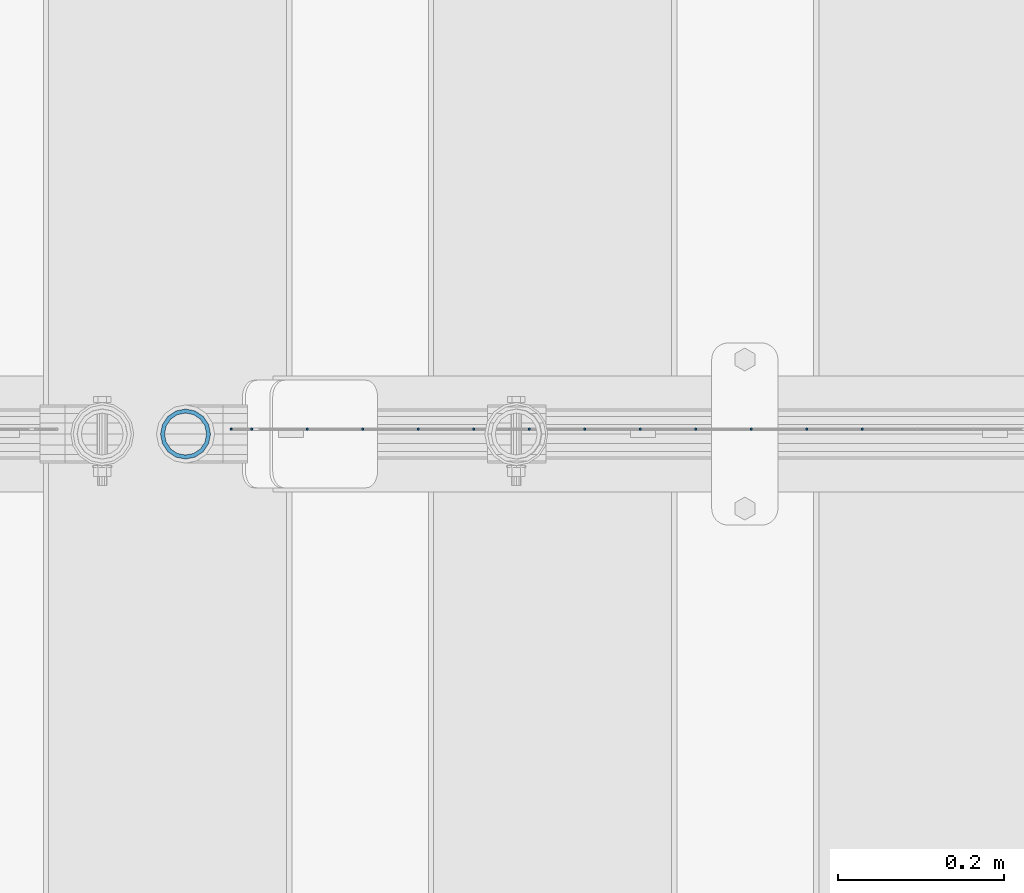
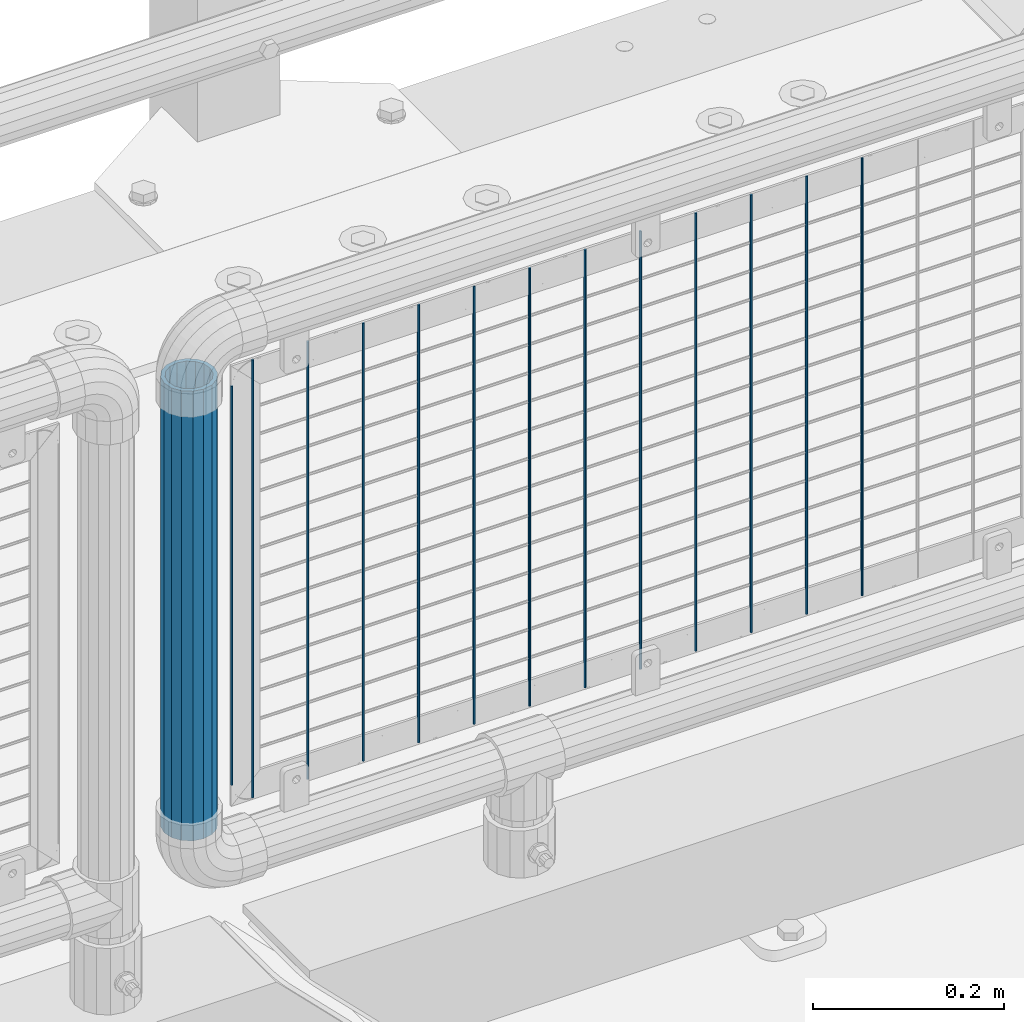
# One storey, part 103 of 247: 14 columns.
"""IFC2X3 building model written with IfcOpenShell, lengths in millimetres."""

from ifc_helpers import new_model, si_unit, frame, origin_with_axes, place, context, subcontext, project, spatial, faceted_brep, material, type_object, element, save


model = new_model("IFC2X3")

# Units and contexts
model_context = context("Model", 3, precision=1e-05, world=origin_with_axes())
body_context = subcontext(model_context, "Body", "Model", "MODEL_VIEW")
ifc_project = project(units=[si_unit("LENGTHUNIT", "METRE", prefix="MILLI"), si_unit("AREAUNIT", "SQUARE_METRE"), si_unit("VOLUMEUNIT", "CUBIC_METRE"), si_unit("MASSUNIT", "GRAM", prefix="KILO"), si_unit("TIMEUNIT", "SECOND"), si_unit("PLANEANGLEUNIT", "RADIAN"), si_unit("SOLIDANGLEUNIT", "STERADIAN"), si_unit("THERMODYNAMICTEMPERATUREUNIT", "DEGREE_CELSIUS"), si_unit("LUMINOUSINTENSITYUNIT", "LUMEN")], contexts=[model_context])

# Site, building, storey
site_placement = place(None, origin_with_axes())
site = spatial("IfcSite", under=ifc_project, at=site_placement, CompositionType="ELEMENT")
building_placement = place(site_placement, origin_with_axes())
building = spatial("IfcBuilding", under=site, at=building_placement, Name="Standard", CompositionType="ELEMENT")
storey_placement = place(building_placement, origin_with_axes())
storey = spatial("IfcBuildingStorey", under=building, at=storey_placement, Name="Undefined", CompositionType="ELEMENT", Elevation=0.0)

# Columns
ifc_material_1 = material()
column_type_1 = type_object("IfcColumnType", PredefinedType="NOTDEFINED")
column_1_placement = place(storey_placement, frame((15121.61, 7664.5, 349.86), z_axis=(-1.0, 0.0, 0.0), x_axis=(0.0, 0.0, 1.0)))
element("IfcColumn", 1, at=column_1_placement, inside=storey, type_object=column_type_1, material=ifc_material_1, context=body_context, shape_type="Brep", body=[
    faceted_brep([(0.0, -25.3500000000004, 0.0), (0.0, -23.4203461491616, 9.70102501045585), (574.992910334213, -23.4203461491616, 9.70102501045585), (574.990000024649, -25.3500000000004, 0.0), (0.0, -17.9251569030794, 17.9251569030785), (574.995377579387, -17.9251569030794, 17.9251569030785), (0.0, -9.70102501045494, 23.4203461491616), (574.997026144459, -9.70102501045494, 23.4203461491616), (0.0, 0.0, 25.3500000000004), (574.997605050341, 0.0, 25.3500000000004), (0.0, 9.70102501045494, 23.4203461491616), (574.997026163861, 9.70102501045494, 23.4203461491616), (0.0, 17.9251569030794, 17.9251569030785), (574.995377615237, 17.9251569030794, 17.9251569030785), (0.0, 23.4203461491616, 9.70102501045585), (574.992910381054, 23.4203461491616, 9.70102501045585), (0.0, 25.3500000000004, 0.0), (574.990000075349, 25.3500000000004, 0.0), (0.0, 23.4203461491616, -9.70102501045585), (574.987089765785, 23.4203461491616, -9.70102501045585), (0.0, 17.9251569030794, -17.9251569030785), (574.984622520612, 17.9251569030794, -17.9251569030785), (0.0, 9.70102501045494, -23.4203461491616), (574.982973955539, 9.70102501045494, -23.4203461491616), (0.0, 0.0, -25.3500000000004), (574.982395049657, 0.0, -25.3500000000004), (0.0, -9.70102501045494, -23.4203461491616), (574.982973936137, -9.70102501045494, -23.4203461491616), (0.0, -17.9251569030794, -17.9251569030785), (574.984622484761, -17.9251569030794, -17.9251569030785), (0.0, -23.4203461491616, -9.70102501045585), (574.987089718945, -23.4203461491616, -9.70102501045585), (0.0, -30.1499999999996, 0.0), (0.0, -27.8549679052148, -11.5379054858076), (574.986538650343, -27.8549679052148, -11.5379054858076), (574.990000019849, -30.1499999999996, 0.0), (0.0, -21.3192694527743, -21.3192694527752), (574.983604247556, -21.3192694527743, -21.3192694527752), (0.0, -11.5379054858076, -27.8549679052157), (574.981643547714, -11.5379054858076, -27.8549679052157), (0.0, 0.0, -30.1499999999996), (574.980955049592, 0.0, -30.1499999999996), (0.0, 11.5379054858076, -27.8549679052157), (574.98164357079, 11.5379054858076, -27.8549679052157), (0.0, 21.3192694527743, -21.3192694527752), (574.983604290195, 21.3192694527743, -21.3192694527752), (0.0, 27.8549679052157, -11.5379054858076), (574.986538706053, 27.8549679052157, -11.5379054858076), (0.0, 30.1499999999996, 0.0), (574.990000080149, 30.1499999999996, 0.0), (0.0, 27.8549679052157, 11.5379054858076), (574.993461449656, 27.8549679052157, 11.5379054858076), (0.0, 21.3192694527743, 21.3192694527752), (574.996395852442, 21.3192694527743, 21.3192694527752), (0.0, 11.5379054858076, 27.8549679052157), (574.998356552285, 11.5379054858076, 27.8549679052157), (0.0, 0.0, 30.1499999999996), (574.999045050406, 0.0, 30.1499999999996), (0.0, -11.5379054858076, 27.8549679052157), (574.998356529209, -11.5379054858076, 27.8549679052157), (0.0, -21.3192694527743, 21.3192694527752), (574.996395809804, -21.3192694527743, 21.3192694527752), (0.0, -27.8549679052157, 11.5379054858076), (574.993461393946, -27.8549679052157, 11.5379054858076)], [[[0, 1, 2, 3]], [[1, 4, 5, 2]], [[4, 6, 7, 5]], [[6, 8, 9, 7]], [[8, 10, 11, 9]], [[10, 12, 13, 11]], [[12, 14, 15, 13]], [[14, 16, 17, 15]], [[16, 18, 19, 17]], [[18, 20, 21, 19]], [[20, 22, 23, 21]], [[22, 24, 25, 23]], [[24, 26, 27, 25]], [[26, 28, 29, 27]], [[28, 30, 31, 29]], [[30, 0, 3, 31]], [[32, 33, 34, 35]], [[33, 36, 37, 34]], [[36, 38, 39, 37]], [[38, 40, 41, 39]], [[40, 42, 43, 41]], [[42, 44, 45, 43]], [[44, 46, 47, 45]], [[46, 48, 49, 47]], [[48, 50, 51, 49]], [[50, 52, 53, 51]], [[52, 54, 55, 53]], [[54, 56, 57, 55]], [[56, 58, 59, 57]], [[58, 60, 61, 59]], [[60, 62, 63, 61]], [[62, 32, 35, 63]], [[37, 39, 41, 43, 45, 47, 49, 51, 53, 55, 57, 59, 61, 63, 35, 34], [5, 7, 9, 11, 13, 15, 17, 19, 21, 23, 25, 27, 29, 31, 3, 2]], [[62, 60, 58, 56, 54, 52, 50, 48, 46, 44, 42, 40, 38, 36, 33, 32], [30, 28, 26, 24, 22, 20, 18, 16, 14, 12, 10, 8, 6, 4, 1, 0]]]),
])
ifc_material_2 = material(Name="Misc_Undefined")
column_type_2 = type_object("IfcColumnType", Name="D3", PredefinedType="NOTDEFINED")
for number, where, z_axis, x_axis in (
    (2, (15938.9180000001, 7670.49982672734, 353.02), (-1.0, 0.0, 0.0), (0.0, 0.0, 1.0)),
    (3, (15871.8900000001, 7670.49984093615, 353.02), (-1.0, 0.0, 0.0), (0.0, 0.0, 1.0)),
    (4, (15804.8620000001, 7670.49985514497, 353.02), (-1.0, 0.0, 0.0), (0.0, 0.0, 1.0)),
    (5, (15737.8340000001, 7670.49986935379, 353.02), (-1.0, 0.0, 0.0), (0.0, 0.0, 1.0)),
    (6, (15536.7500000001, 7670.49991198024, 353.02), (-1.0, 0.0, 0.0), (0.0, 0.0, 1.0)),
    (7, (15469.7220000001, 7670.49992618905, 353.02), (-1.0, 0.0, 0.0), (0.0, 0.0, 1.0)),
    (8, (15402.694, 7670.49994039787, 353.02), (-1.0, 0.0, 0.0), (0.0, 0.0, 1.0)),
    (9, (15603.7780000001, 7670.49989777142, 353.02), (-1.0, 0.0, 0.0), (0.0, 0.0, 1.0)),
    (10, (15335.666, 7670.49995460668, 353.02), (-1.0, 0.0, 0.0), (0.0, 0.0, 1.0)),
    (11, (15670.8060000001, 7670.4998835626, 353.02), (-1.0, 0.0, 0.0), (0.0, 0.0, 1.0)),
    (12, (15268.638, 7670.4999688155, 353.02), (-1.0, 0.0, 0.0), (0.0, 0.0, 1.0)),
):
    element("IfcColumn", number, at=place(storey_placement, frame(where, z_axis=z_axis, x_axis=x_axis)), inside=storey, type_object=column_type_2, material=ifc_material_2, ObjectType="D3", context=body_context, shape_type="Brep", body=[
        faceted_brep([(1.81898940354586e-12, -1.5, -5.6843418860808e-14), (0.0, -0.75, -1.29903810567703), (560.0, -0.75, -1.29903810567703), (560.0, -1.5, 0.0), (0.0, 0.75, -1.29903810567703), (560.0, 0.75, -1.29903810567703), (1.81898940354586e-12, 1.5, -5.6843418860808e-14), (560.0, 1.5, 0.0), (0.0, 0.75, 1.29903810567703), (560.0, 0.75, 1.29903810567703), (0.0, -0.75, 1.29903810567703), (560.0, -0.75, 1.29903810567703)], [[[0, 1, 2, 3]], [[1, 4, 5, 2]], [[4, 6, 7, 5]], [[6, 8, 9, 7]], [[8, 10, 11, 9]], [[10, 0, 3, 11]], [[5, 7, 9, 11, 3, 2]], [[10, 8, 6, 4, 1, 0]]]),
    ])
column_2_placement = place(storey_placement, frame((15176.61, 7670.49998832922, 378.02), z_axis=(-1.0, 0.0, 0.0), x_axis=(0.0, 0.0, 1.0)))
element("IfcColumn", 13, at=column_2_placement, inside=storey, type_object=column_type_2, material=ifc_material_2, ObjectType="D3", context=body_context, shape_type="Brep", body=[
    faceted_brep([(1.81898940354586e-12, -1.5, -5.6843418860808e-14), (0.0, -0.75, -1.29903810567703), (510.0, -0.75, -1.29903810567703), (510.0, -1.5, 0.0), (0.0, 0.75, -1.29903810567703), (510.0, 0.75, -1.29903810567703), (1.81898940354586e-12, 1.5, -5.6843418860808e-14), (510.0, 1.5, 0.0), (0.0, 0.75, 1.29903810567703), (510.0, 0.75, 1.29903810567703), (0.0, -0.75, 1.29903810567703), (510.0, -0.75, 1.29903810567703)], [[[0, 1, 2, 3]], [[1, 4, 5, 2]], [[4, 6, 7, 5]], [[6, 8, 9, 7]], [[8, 10, 11, 9]], [[10, 0, 3, 11]], [[5, 7, 9, 11, 3, 2]], [[10, 8, 6, 4, 1, 0]]]),
])
column_3_placement = place(storey_placement, frame((15201.61, 7670.49998302432, 353.02), z_axis=(-1.0, 0.0, 0.0), x_axis=(0.0, 0.0, 1.0)))
element("IfcColumn", 14, at=column_3_placement, inside=storey, type_object=column_type_2, material=ifc_material_2, ObjectType="D3", context=body_context, shape_type="Brep", body=[
    faceted_brep([(1.81898940354586e-12, -1.5, -5.6843418860808e-14), (0.0, -0.75, -1.29903810567703), (560.0, -0.75, -1.29903810567703), (560.0, -1.5, 0.0), (0.0, 0.75, -1.29903810567703), (560.0, 0.75, -1.29903810567703), (1.81898940354586e-12, 1.5, -5.6843418860808e-14), (560.0, 1.5, 0.0), (0.0, 0.75, 1.29903810567703), (560.0, 0.75, 1.29903810567703), (0.0, -0.75, 1.29903810567703), (560.0, -0.75, 1.29903810567703)], [[[0, 1, 2, 3]], [[1, 4, 5, 2]], [[4, 6, 7, 5]], [[6, 8, 9, 7]], [[8, 10, 11, 9]], [[10, 0, 3, 11]], [[5, 7, 9, 11, 3, 2]], [[10, 8, 6, 4, 1, 0]]]),
])

save(model, "model.ifc")
